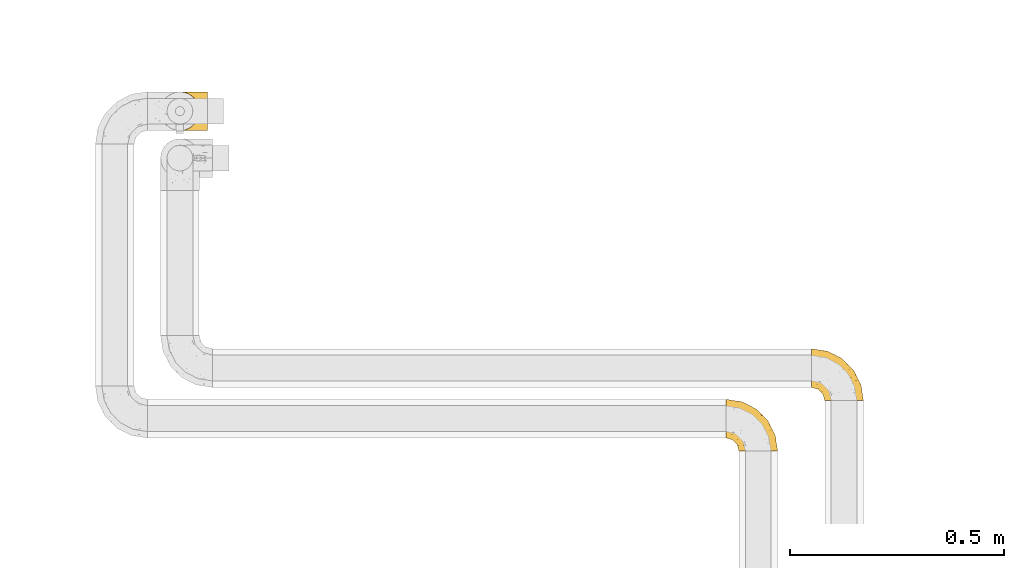
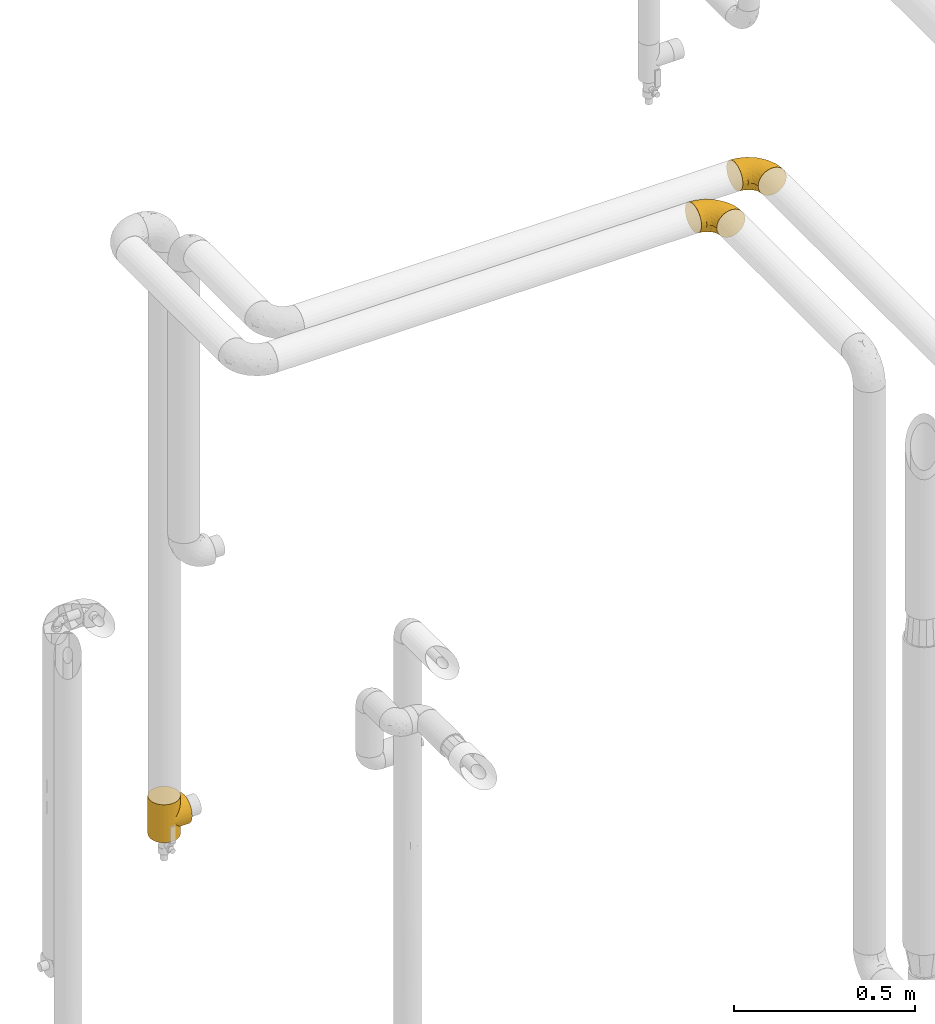
# One storey, part 118 of 827: 3 coverings.
"""IFC2X3 building model written with IfcOpenShell, lengths in millimetres."""

from ifc_helpers import new_model, entity, si_unit, converted_unit, derived_unit, direction, frame, origin, place, context, subcontext, project, spatial, faceted_brep, element, save


model = new_model("IFC2X3")

# Units and contexts
model_context = context("Model", 3, precision=0.01, world=origin(), true_north=direction((6.12303176911189e-17, 1.0)))
body_context = subcontext(model_context, "Body", "Model", "MODEL_VIEW")
ifc_project = project(units=[si_unit("LENGTHUNIT", "METRE", prefix="MILLI"), si_unit("AREAUNIT", "SQUARE_METRE"), si_unit("VOLUMEUNIT", "CUBIC_METRE"), converted_unit("PLANEANGLEUNIT", "DEGREE", entity("IfcRatioMeasure", 0.0174532925199433), si_unit("PLANEANGLEUNIT", "RADIAN"), dimensions=[0, 0, 0, 0, 0, 0, 0]), si_unit("MASSUNIT", "GRAM", prefix="KILO"), derived_unit("MASSDENSITYUNIT", [(si_unit("MASSUNIT", "GRAM", prefix="KILO"), 1), (si_unit("LENGTHUNIT", "METRE"), -3)]), derived_unit("MOMENTOFINERTIAUNIT", [(si_unit("LENGTHUNIT", "METRE"), 4)]), si_unit("TIMEUNIT", "SECOND"), si_unit("FREQUENCYUNIT", "HERTZ"), si_unit("THERMODYNAMICTEMPERATUREUNIT", "DEGREE_CELSIUS"), derived_unit("THERMALTRANSMITTANCEUNIT", [(si_unit("MASSUNIT", "GRAM", prefix="KILO"), 1), (si_unit("THERMODYNAMICTEMPERATUREUNIT", "KELVIN"), -1), (si_unit("TIMEUNIT", "SECOND"), -3)]), derived_unit("VOLUMETRICFLOWRATEUNIT", [(si_unit("LENGTHUNIT", "METRE"), 3), (si_unit("TIMEUNIT", "SECOND"), -1)]), derived_unit("MASSFLOWRATEUNIT", [(si_unit("MASSUNIT", "GRAM", prefix="KILO"), 1), (si_unit("TIMEUNIT", "SECOND"), -1)]), derived_unit("ROTATIONALFREQUENCYUNIT", [(si_unit("TIMEUNIT", "SECOND"), -1)]), si_unit("ELECTRICCURRENTUNIT", "AMPERE"), si_unit("ELECTRICVOLTAGEUNIT", "VOLT"), si_unit("POWERUNIT", "WATT"), si_unit("FORCEUNIT", "NEWTON", prefix="KILO"), si_unit("ILLUMINANCEUNIT", "LUX"), si_unit("LUMINOUSFLUXUNIT", "LUMEN"), si_unit("LUMINOUSINTENSITYUNIT", "CANDELA"), derived_unit("USERDEFINED", [(si_unit("MASSUNIT", "GRAM", prefix="KILO"), -1), (si_unit("LENGTHUNIT", "METRE"), -2), (si_unit("TIMEUNIT", "SECOND"), 3), (si_unit("LUMINOUSFLUXUNIT", "LUMEN"), 1)]), derived_unit("LINEARVELOCITYUNIT", [(si_unit("LENGTHUNIT", "METRE"), 1), (si_unit("TIMEUNIT", "SECOND"), -1)]), si_unit("PRESSUREUNIT", "PASCAL"), derived_unit("USERDEFINED", [(si_unit("LENGTHUNIT", "METRE"), -2), (si_unit("MASSUNIT", "GRAM", prefix="KILO"), 1), (si_unit("TIMEUNIT", "SECOND"), -2)]), derived_unit("LINEARFORCEUNIT", [(si_unit("MASSUNIT", "GRAM", prefix="KILO"), 1), (si_unit("LENGTHUNIT", "METRE"), 1), (si_unit("TIMEUNIT", "SECOND"), -2), (si_unit("LENGTHUNIT", "METRE"), -1)]), derived_unit("PLANARFORCEUNIT", [(si_unit("MASSUNIT", "GRAM", prefix="KILO"), 1), (si_unit("LENGTHUNIT", "METRE"), 1), (si_unit("TIMEUNIT", "SECOND"), -2), (si_unit("LENGTHUNIT", "METRE"), -2)])], contexts=[model_context])

# Site, building, storey
site_placement = place(None, origin())
site = spatial("IfcSite", under=ifc_project, at=site_placement, CompositionType="ELEMENT")
building_placement = place(site_placement, origin())
building = spatial("IfcBuilding", under=site, at=building_placement, CompositionType="ELEMENT")
storey_placement = place(building_placement, frame((0.0, 0.0, 28200.0)))
storey = spatial("IfcBuildingStorey", under=building, at=storey_placement, Name="08", CompositionType="ELEMENT", Elevation=28200.0)

# Coverings
covering_1_placement = place(storey_placement, frame((21222.65, 12443.23, 2353.25)))
element("IfcCovering", 1, at=covering_1_placement, inside=storey, Name=":ADSK_", ObjectType=":ADSK_", PredefinedType="INSULATION", context=body_context, shape_type="Brep", body=[
    faceted_brep([(1.6, 87.65, 90.76), (1.6, 97.19, 87.42), (1.6, 105.75, 82.04), (1.6, 112.9, 74.89), (1.6, 118.28, 66.33), (1.6, 121.61, 56.79), (1.6, 122.75, 46.75), (1.6, 121.61, 36.69), (1.6, 118.27, 27.15), (1.6, 112.89, 18.59), (1.6, 105.74, 11.44), (1.6, 97.18, 6.06), (1.6, 87.64, 2.73), (1.6, 77.6, 1.6), (1.6, 67.54, 2.73), (1.6, 58.0, 6.07), (1.6, 49.44, 11.45), (1.6, 42.29, 18.6), (1.6, 36.91, 27.16), (1.6, 33.58, 36.7), (1.6, 32.45, 46.75), (1.6, 33.58, 56.8), (1.6, 36.92, 66.34), (1.6, 42.3, 74.9), (1.6, 49.45, 82.05), (1.6, 58.01, 87.43), (1.6, 67.55, 90.76), (1.6, 77.6, 91.9), (33.98, 1.6, 35.06), (38.49, 1.6, 24.17), (45.67, 1.6, 14.82), (55.02, 1.6, 7.64), (65.91, 1.6, 3.13), (77.6, 1.6, 1.6), (89.28, 1.6, 3.13), (100.17, 1.6, 7.64), (109.52, 1.6, 14.82), (116.7, 1.6, 24.17), (121.21, 1.6, 35.06), (122.75, 1.6, 46.75), (121.21, 1.6, 58.43), (116.7, 1.6, 69.32), (109.52, 1.6, 78.67), (100.17, 1.6, 85.85), (89.28, 1.6, 90.36), (77.6, 1.6, 91.9), (65.91, 1.6, 90.36), (55.02, 1.6, 85.85), (45.67, 1.6, 78.67), (38.49, 1.6, 69.32), (33.98, 1.6, 58.43), (32.45, 1.6, 46.75), (72.81, 99.61, 46.75), (77.17, 95.26, 55.2), (86.21, 86.21, 46.75), (116.82, 39.03, 46.75), (118.49, 30.75, 54.53), (119.23, 23.8, 46.75), (105.14, 60.8, 59.63), (85.37, 85.37, 62.07), (89.33, 73.64, 71.86), (116.14, 31.01, 62.65), (105.06, 49.14, 71.33), (112.15, 23.88, 72.93), (22.95, 82.74, 91.2), (89.91, 43.48, 86.31), (103.39, 29.47, 80.89), (93.6, 56.38, 79.49), (51.41, 72.18, 90.68), (67.71, 72.24, 86.84), (43.53, 87.6, 87.38), (30.91, 107.24, 76.87), (23.58, 101.1, 83.73), (50.07, 95.16, 81.03), (30.68, 71.81, 91.9), (43.01, 63.57, 91.9), (55.34, 55.34, 91.9), (83.48, 23.66, 91.03), (94.96, 20.55, 87.58), (57.29, 107.97, 56.52), (39.03, 116.82, 46.75), (30.66, 117.03, 60.4), (71.81, 30.68, 91.9), (73.63, 21.51, 91.9), (75.46, 12.33, 91.9), (51.57, 106.17, 67.87), (73.13, 52.37, 90.35), (23.16, 114.51, 69.57), (23.8, 119.23, 46.75), (75.6, 78.37, 79.91), (12.33, 75.46, 91.9), (21.51, 73.63, 91.9), (50.46, 101.51, 74.99), (99.61, 72.81, 46.75), (63.57, 43.01, 91.9), (21.26, 92.6, 88.53), (69.54, 91.86, 72.65), (108.21, 55.92, 46.75), (68.42, 99.01, 62.97), (55.92, 108.21, 46.75), (19.36, 32.05, 66.2), (15.76, 30.22, 56.6), (26.13, 23.37, 59.89), (62.78, 28.43, 90.95), (63.65, 16.44, 90.22), (24.34, 37.1, 76.64), (28.46, 28.88, 71.58), (33.53, 33.93, 79.99), (39.46, 50.17, 89.54), (51.05, 40.57, 89.97), (10.94, 47.62, 81.32), (14.55, 39.9, 74.56), (22.21, 47.92, 84.15), (57.05, 34.27, 90.37), (54.0, 24.65, 87.82), (29.19, 62.6, 90.98), (18.85, 66.18, 90.96), (52.84, 11.74, 85.14), (31.47, 13.89, 58.11), (28.31, 17.02, 46.75), (43.0, 15.86, 78.39), (16.9, 57.71, 88.22), (35.98, 9.11, 66.06), (33.91, 18.55, 68.6), (9.97, 34.74, 63.78), (25.93, 54.95, 88.42), (35.61, 57.35, 90.61), (47.45, 22.03, 83.8), (38.26, 24.8, 77.98), (11.7, 69.07, 91.22), (30.13, 42.31, 83.46), (12.12, 29.63, 46.75), (17.02, 28.31, 46.75), (44.39, 30.23, 84.66), (39.83, 40.13, 86.33), (22.67, 22.67, 46.75), (29.63, 12.12, 46.75), (43.0, 15.86, 15.1), (47.45, 22.03, 9.69), (38.26, 24.8, 15.52), (44.38, 30.23, 8.83), (31.47, 13.88, 35.39), (10.93, 47.61, 12.18), (21.51, 73.63, 1.6), (18.84, 66.17, 2.53), (11.7, 69.07, 2.27), (15.76, 30.22, 36.9), (19.36, 32.04, 27.31), (26.14, 23.36, 33.62), (25.94, 54.93, 5.07), (22.21, 47.91, 9.36), (16.9, 57.69, 5.27), (35.98, 9.1, 27.43), (73.63, 21.51, 1.6), (75.46, 12.33, 1.6), (30.12, 42.29, 10.05), (24.33, 37.09, 16.87), (52.84, 11.74, 8.35), (63.65, 16.44, 3.27), (71.81, 30.68, 1.6), (28.45, 28.86, 21.94), (9.97, 34.74, 29.72), (43.01, 63.57, 1.6), (55.34, 55.34, 1.6), (39.46, 50.17, 3.96), (12.33, 75.46, 1.6), (14.54, 39.89, 18.95), (62.78, 28.43, 2.54), (57.05, 34.27, 3.12), (63.57, 43.01, 1.6), (29.2, 62.59, 2.51), (51.05, 40.57, 3.52), (39.81, 40.13, 7.17), (30.68, 71.81, 1.6), (33.52, 33.92, 13.52), (35.61, 57.34, 2.88), (54.0, 24.65, 5.67), (33.91, 18.54, 24.89), (103.39, 29.47, 12.6), (89.91, 43.48, 7.18), (93.6, 56.4, 14.0), (105.05, 49.17, 22.16), (89.27, 73.69, 21.61), (73.13, 52.37, 3.14), (67.67, 72.26, 6.65), (69.49, 91.88, 20.82), (85.36, 85.36, 31.41), (94.96, 20.55, 5.91), (83.48, 23.66, 2.46), (105.14, 60.8, 33.87), (116.13, 31.02, 30.84), (118.49, 30.75, 38.96), (112.15, 23.9, 20.56), (51.41, 72.17, 2.81), (43.51, 87.59, 6.1), (22.95, 82.74, 2.29), (30.66, 117.03, 33.08), (30.91, 107.23, 16.61), (57.3, 107.97, 36.96), (23.58, 101.08, 9.75), (51.56, 106.17, 25.61), (68.41, 99.01, 30.5), (23.16, 114.5, 23.91), (50.07, 95.15, 12.45), (50.45, 101.5, 18.49), (21.25, 92.59, 4.96), (75.56, 78.38, 13.56), (77.16, 95.27, 38.28)], [[[0, 1, 2, 3, 4, 5, 6, 7, 8, 9, 10, 11, 12, 13, 14, 15, 16, 17, 18, 19, 20, 21, 22, 23, 24, 25, 26, 27]], [[28, 29, 30, 31, 32, 33, 34, 35, 36, 37, 38, 39, 40, 41, 42, 43, 44, 45, 46, 47, 48, 49, 50, 51]], [[52, 53, 54]], [[55, 56, 57]], [[58, 59, 60]], [[61, 62, 63]], [[27, 64, 0]], [[65, 66, 67]], [[41, 40, 61]], [[68, 69, 70]], [[66, 43, 42]], [[63, 42, 41]], [[71, 72, 73]], [[72, 2, 1]], [[68, 74, 75, 76]], [[45, 44, 77]], [[43, 78, 44]], [[79, 80, 81]], [[77, 82, 83, 84, 45]], [[79, 81, 85]], [[71, 2, 72]], [[65, 86, 77]], [[4, 81, 5]], [[66, 65, 78]], [[4, 3, 87]], [[81, 88, 5]], [[63, 66, 42]], [[68, 70, 64]], [[67, 60, 89]], [[71, 3, 2]], [[64, 27, 90, 91, 74]], [[92, 71, 73]], [[40, 57, 56]], [[59, 93, 54]], [[86, 76, 94, 82]], [[1, 0, 95]], [[58, 62, 61]], [[60, 96, 89]], [[85, 81, 87]], [[56, 97, 58]], [[65, 67, 69]], [[87, 81, 4]], [[67, 89, 69]], [[61, 63, 41]], [[95, 72, 1]], [[73, 72, 70]], [[69, 73, 70]], [[73, 89, 96]], [[3, 71, 87]], [[85, 87, 71]], [[58, 61, 56]], [[59, 58, 93]], [[76, 86, 68]], [[69, 89, 73]], [[68, 86, 69]], [[65, 69, 86]], [[68, 64, 74]], [[95, 64, 70]], [[98, 79, 85]], [[79, 52, 99, 80]], [[66, 62, 67]], [[62, 58, 60]], [[62, 60, 67]], [[59, 98, 96]], [[59, 96, 60]], [[96, 85, 92]], [[88, 81, 80]], [[88, 6, 5]], [[66, 63, 62]], [[64, 95, 0]], [[72, 95, 70]], [[77, 44, 78]], [[86, 82, 77]], [[40, 39, 57]], [[96, 98, 85]], [[40, 56, 61]], [[66, 78, 43]], [[77, 78, 65]], [[79, 98, 53]], [[96, 92, 73]], [[85, 71, 92]], [[97, 56, 55]], [[97, 93, 58]], [[53, 98, 59]], [[54, 53, 59]], [[79, 53, 52]], [[100, 101, 102]], [[46, 45, 84, 83]], [[103, 104, 82]], [[82, 104, 83]], [[105, 106, 107]], [[108, 109, 76]], [[110, 111, 112]], [[103, 113, 114]], [[115, 74, 116]], [[48, 47, 117]], [[118, 102, 119]], [[49, 48, 120]], [[74, 91, 116]], [[116, 121, 115]], [[49, 122, 50]], [[123, 106, 102]], [[124, 111, 22]], [[125, 126, 115]], [[23, 22, 111]], [[24, 110, 121]], [[120, 127, 128]], [[90, 26, 129]], [[27, 26, 90]], [[121, 125, 115]], [[24, 121, 25]], [[130, 105, 107]], [[129, 25, 116]], [[21, 20, 131]], [[120, 123, 122]], [[112, 105, 130]], [[50, 118, 51]], [[21, 124, 22]], [[101, 131, 132]], [[117, 120, 48]], [[24, 23, 110]], [[127, 114, 133]], [[75, 108, 76]], [[107, 134, 130]], [[133, 114, 113]], [[129, 116, 91]], [[25, 121, 116]], [[121, 112, 125]], [[75, 74, 115]], [[101, 135, 102]], [[131, 101, 21]], [[101, 100, 124]], [[128, 127, 133]], [[119, 136, 51, 118]], [[104, 47, 46]], [[83, 104, 46]], [[117, 104, 114]], [[101, 124, 21]], [[111, 124, 100]], [[102, 118, 123]], [[133, 134, 107]], [[111, 110, 23]], [[114, 104, 103]], [[94, 76, 109]], [[121, 110, 112]], [[122, 118, 50]], [[134, 109, 108]], [[133, 107, 128]], [[112, 108, 125]], [[126, 125, 108]], [[108, 75, 126]], [[75, 115, 126]], [[109, 134, 133]], [[130, 108, 112]], [[108, 130, 134]], [[105, 112, 111]], [[111, 100, 105]], [[106, 105, 100]], [[102, 106, 100]], [[128, 106, 123]], [[90, 129, 91]], [[25, 129, 26]], [[104, 117, 47]], [[117, 114, 127]], [[82, 94, 103]], [[113, 94, 109]], [[94, 113, 103]], [[133, 113, 109]], [[106, 128, 107]], [[123, 120, 128]], [[120, 122, 49]], [[118, 122, 123]], [[135, 101, 132]], [[135, 119, 102]], [[117, 127, 120]], [[30, 29, 137]], [[138, 139, 140]], [[51, 136, 119, 141]], [[142, 17, 16]], [[143, 144, 145]], [[146, 147, 148]], [[149, 150, 151]], [[152, 29, 28]], [[33, 32, 153, 154]], [[150, 155, 156]], [[157, 31, 30]], [[153, 158, 159]], [[29, 152, 137]], [[148, 141, 119]], [[156, 160, 147]], [[148, 135, 146]], [[137, 138, 157]], [[19, 161, 146]], [[162, 163, 164]], [[14, 13, 165]], [[153, 32, 158]], [[147, 161, 166]], [[18, 17, 166]], [[167, 168, 169]], [[166, 150, 156]], [[151, 150, 142]], [[151, 170, 149]], [[151, 16, 15]], [[171, 140, 172]], [[165, 143, 145]], [[173, 170, 144]], [[142, 166, 17]], [[19, 131, 20]], [[144, 170, 151]], [[18, 161, 19]], [[173, 144, 143]], [[140, 139, 174]], [[171, 164, 163]], [[164, 172, 155]], [[151, 15, 144]], [[145, 15, 14]], [[173, 162, 170]], [[149, 175, 164]], [[19, 146, 131]], [[132, 131, 146]], [[160, 148, 147]], [[159, 158, 167]], [[135, 132, 146]], [[158, 32, 31]], [[157, 158, 31]], [[167, 158, 176]], [[166, 161, 18]], [[146, 161, 147]], [[148, 177, 141]], [[171, 168, 140]], [[171, 163, 169]], [[151, 142, 16]], [[166, 142, 150]], [[152, 141, 177]], [[51, 141, 28]], [[138, 140, 176]], [[172, 140, 174]], [[175, 149, 170]], [[164, 150, 149]], [[170, 162, 175]], [[162, 164, 175]], [[155, 172, 174]], [[171, 172, 164]], [[155, 174, 156]], [[164, 155, 150]], [[160, 156, 174]], [[147, 166, 156]], [[139, 160, 174]], [[148, 160, 177]], [[15, 145, 144]], [[165, 145, 14]], [[137, 157, 30]], [[158, 157, 176]], [[168, 167, 176]], [[169, 159, 167]], [[140, 168, 176]], [[169, 168, 171]], [[137, 177, 139]], [[160, 139, 177]], [[141, 152, 28]], [[137, 152, 177]], [[148, 119, 135]], [[157, 138, 176]], [[139, 138, 137]], [[178, 179, 180]], [[181, 180, 182]], [[179, 183, 184]], [[185, 186, 182]], [[187, 188, 179]], [[188, 33, 154, 153, 159]], [[181, 189, 190]], [[35, 34, 187]], [[191, 38, 190]], [[192, 178, 181]], [[179, 184, 180]], [[192, 190, 37]], [[37, 190, 38]], [[36, 35, 178]], [[54, 93, 186]], [[35, 187, 178]], [[193, 194, 184]], [[195, 173, 143, 165, 13]], [[195, 193, 173]], [[193, 163, 162, 173]], [[13, 12, 195]], [[8, 7, 196]], [[9, 197, 10]], [[198, 80, 99, 52]], [[196, 7, 88]], [[197, 199, 10]], [[182, 189, 181]], [[200, 198, 201]], [[200, 196, 198]], [[9, 8, 202]], [[194, 199, 203]], [[192, 37, 36]], [[80, 196, 88]], [[183, 159, 169, 163]], [[188, 34, 33]], [[202, 200, 197]], [[185, 203, 204]], [[202, 8, 196]], [[10, 199, 11]], [[12, 11, 205]], [[38, 191, 57]], [[189, 97, 191]], [[203, 199, 197]], [[205, 199, 194]], [[204, 203, 197]], [[184, 203, 206]], [[200, 202, 196]], [[197, 9, 202]], [[207, 54, 186]], [[97, 55, 191]], [[194, 203, 184]], [[183, 163, 193]], [[184, 206, 180]], [[183, 193, 184]], [[205, 195, 12]], [[193, 195, 194]], [[80, 198, 196]], [[207, 186, 201]], [[182, 180, 206]], [[181, 178, 180]], [[185, 182, 206]], [[182, 186, 189]], [[203, 185, 206]], [[185, 200, 201]], [[7, 6, 88]], [[178, 192, 36]], [[190, 192, 181]], [[199, 205, 11]], [[195, 205, 194]], [[159, 183, 188]], [[179, 188, 183]], [[57, 191, 55]], [[57, 39, 38]], [[189, 191, 190]], [[188, 187, 34]], [[178, 187, 179]], [[186, 93, 189]], [[197, 200, 204]], [[185, 204, 200]], [[189, 93, 97]], [[207, 198, 52]], [[185, 201, 186]], [[198, 207, 201]], [[54, 207, 52]]]),
])
covering_2_placement = place(storey_placement, frame((19703.25, 13073.62, 333.5)))
element("IfcCovering", 2, at=covering_2_placement, inside=storey, Name=":ADSK_", ObjectType=":ADSK_", PredefinedType="INSULATION", context=body_context, shape_type="Brep", body=[
    faceted_brep([(53.5, 2.1, 57.25), (46.75, 1.6, 0.0), (58.43, 3.13, 0.0), (69.32, 7.64, 0.0), (66.68, 6.23, 44.06), (72.92, 9.95, 37.83), (78.67, 14.82, 0.0), (46.75, 1.6, 64.0), (53.5, 2.1, 70.75), (46.75, 1.6, 128.0), (60.17, 3.64, 50.57), (83.88, 21.07, 26.86), (85.85, 24.17, 0.0), (88.08, 28.59, 22.66), (88.1, 29.61, 0.0), (90.36, 35.06, 0.0), (90.9, 37.3, 19.85), (91.9, 46.75, 0.0), (78.72, 14.87, 32.02), (91.9, 46.75, 18.85), (91.9, 46.75, 128.0), (90.9, 37.3, 108.15), (91.9, 46.75, 109.15), (90.63, 57.34, 20.11), (90.36, 58.43, 0.0), (87.15, 66.9, 23.6), (85.85, 69.32, 0.0), (82.05, 74.89, 28.7), (78.67, 78.67, 0.0), (90.63, 57.34, 107.89), (75.89, 81.23, 34.86), (69.06, 85.99, 41.68), (69.32, 85.85, 0.0), (61.82, 89.3, 48.92), (58.43, 90.36, 0.0), (54.34, 91.25, 56.41), (46.75, 91.9, 0.0), (46.75, 91.9, 64.0), (54.34, 91.25, 71.59), (46.75, 91.9, 128.0), (7.64, 69.32, 128.0), (3.13, 58.43, 128.0), (1.6, 46.75, 128.0), (3.13, 35.06, 128.0), (7.64, 24.17, 128.0), (14.82, 14.82, 128.0), (24.17, 7.64, 128.0), (35.06, 3.13, 128.0), (58.43, 3.13, 128.0), (69.32, 7.64, 128.0), (78.67, 14.82, 128.0), (85.85, 24.17, 128.0), (88.1, 29.61, 128.0), (90.36, 35.06, 128.0), (90.36, 58.43, 128.0), (85.85, 69.32, 128.0), (78.67, 78.67, 128.0), (69.32, 85.85, 128.0), (58.43, 90.36, 128.0), (35.06, 90.36, 128.0), (24.17, 85.85, 128.0), (14.82, 78.67, 128.0), (14.82, 14.82, 0.0), (7.64, 24.17, 0.0), (3.13, 35.06, 0.0), (1.6, 46.75, 0.0), (3.13, 58.43, 0.0), (7.64, 69.32, 0.0), (14.82, 78.67, 0.0), (24.17, 85.85, 0.0), (35.06, 90.36, 0.0), (35.06, 3.13, 0.0), (24.17, 7.64, 0.0), (60.17, 3.64, 77.43), (66.68, 6.23, 83.94), (72.92, 9.95, 90.17), (78.72, 14.87, 95.98), (83.88, 21.07, 101.14), (88.08, 28.59, 105.34), (87.15, 66.9, 104.4), (82.05, 74.89, 99.3), (75.89, 81.23, 93.14), (69.06, 85.99, 86.32), (61.82, 89.3, 79.08), (110.75, 14.82, 32.07), (110.75, 24.17, 24.9), (110.75, 29.61, 22.64), (110.75, 35.06, 20.39), (110.75, 46.75, 18.85), (110.75, 58.43, 20.39), (110.75, 69.32, 24.9), (110.75, 78.67, 32.07), (110.75, 85.85, 41.42), (110.75, 90.36, 52.31), (110.75, 91.9, 64.0), (110.75, 90.36, 75.69), (110.75, 85.85, 86.57), (110.75, 78.67, 95.93), (110.75, 69.32, 103.1), (110.75, 58.43, 107.61), (110.75, 46.75, 109.15), (110.75, 35.06, 107.61), (110.75, 29.61, 105.36), (110.75, 24.17, 103.1), (110.75, 14.82, 95.93), (110.75, 7.64, 86.57), (110.75, 3.13, 75.69), (110.75, 1.6, 64.0), (110.75, 3.13, 52.31), (110.75, 7.64, 41.42)], [[[0, 1, 2]], [[2, 3, 4]], [[5, 3, 6]], [[5, 4, 3]], [[0, 7, 1]], [[7, 8, 9]], [[4, 10, 2]], [[0, 2, 10]], [[11, 6, 12]], [[13, 12, 14, 15]], [[16, 15, 17]], [[11, 18, 6]], [[16, 13, 15]], [[19, 16, 17]], [[20, 21, 22]], [[11, 12, 13]], [[6, 18, 5]], [[23, 17, 24]], [[25, 24, 26]], [[27, 26, 28]], [[23, 19, 17]], [[22, 29, 20]], [[27, 25, 26]], [[23, 24, 25]], [[28, 30, 27]], [[31, 30, 32]], [[32, 30, 28]], [[33, 32, 34]], [[35, 34, 36]], [[33, 31, 32]], [[37, 35, 36]], [[38, 37, 39]], [[33, 34, 35]], [[40, 41, 42, 43, 44, 45, 46, 47, 9, 48, 49, 50, 51, 52, 53, 20, 54, 55, 56, 57, 58, 39, 59, 60, 61]], [[62, 63, 64, 65, 66, 67, 68, 69, 70, 36, 34, 32, 28, 26, 24, 17, 15, 14, 12, 6, 3, 2, 1, 71, 72]], [[63, 62, 45, 44]], [[42, 65, 64, 43]], [[44, 43, 64, 63]], [[46, 72, 71, 47]], [[1, 7, 9, 47, 71]], [[45, 62, 72, 46]], [[73, 74, 48]], [[8, 73, 48]], [[9, 8, 48]], [[49, 75, 50]], [[49, 48, 74]], [[75, 49, 74]], [[76, 77, 50]], [[78, 21, 53]], [[78, 53, 52, 51]], [[77, 78, 51]], [[50, 77, 51]], [[21, 20, 53]], [[76, 50, 75]], [[79, 80, 55]], [[29, 79, 54]], [[20, 29, 54]], [[54, 79, 55]], [[80, 56, 55]], [[80, 81, 56]], [[82, 83, 57]], [[83, 38, 58]], [[81, 57, 56]], [[81, 82, 57]], [[57, 83, 58]], [[38, 39, 58]], [[37, 36, 70, 59, 39]], [[59, 70, 69, 60]], [[69, 68, 61, 60]], [[61, 68, 67, 40]], [[40, 67, 66, 41]], [[41, 66, 65, 42]], [[84, 85, 86, 87, 88, 89, 90, 91, 92, 93, 94, 95, 96, 97, 98, 99, 100, 101, 102, 103, 104, 105, 106, 107, 108, 109]], [[16, 19, 88]], [[16, 88, 87]], [[13, 87, 86, 85]], [[13, 16, 87]], [[84, 18, 11]], [[13, 85, 11]], [[11, 85, 84]], [[5, 84, 109]], [[4, 109, 108]], [[0, 108, 107]], [[4, 5, 109]], [[0, 10, 108]], [[7, 0, 107]], [[4, 108, 10]], [[84, 5, 18]], [[8, 107, 106]], [[106, 105, 74]], [[75, 105, 104]], [[75, 74, 105]], [[8, 7, 107]], [[74, 73, 106]], [[8, 106, 73]], [[77, 104, 103]], [[78, 103, 102, 101]], [[21, 101, 100]], [[77, 76, 104]], [[21, 78, 101]], [[22, 21, 100]], [[77, 103, 78]], [[104, 76, 75]], [[29, 100, 99]], [[79, 99, 98]], [[80, 98, 97]], [[29, 22, 100]], [[80, 79, 98]], [[29, 99, 79]], [[97, 81, 80]], [[82, 81, 96]], [[96, 81, 97]], [[83, 96, 95]], [[38, 95, 94]], [[83, 82, 96]], [[37, 38, 94]], [[83, 95, 38]], [[35, 94, 93]], [[93, 92, 33]], [[30, 92, 91]], [[30, 31, 92]], [[35, 37, 94]], [[31, 33, 92]], [[35, 93, 33]], [[27, 91, 90]], [[25, 90, 89]], [[23, 89, 88]], [[25, 27, 90]], [[19, 23, 88]], [[25, 89, 23]], [[91, 27, 30]]]),
])
covering_3_placement = place(storey_placement, frame((21022.46, 12325.27, 2353.25)))
element("IfcCovering", 3, at=covering_3_placement, inside=storey, Name=":ADSK_", ObjectType=":ADSK_", PredefinedType="INSULATION", context=body_context, shape_type="Brep", body=[
    faceted_brep([(1.6, 87.65, 90.76), (1.6, 97.19, 87.42), (1.6, 105.75, 82.04), (1.6, 112.9, 74.89), (1.6, 118.28, 66.33), (1.6, 121.61, 56.79), (1.6, 122.75, 46.75), (1.6, 121.61, 36.69), (1.6, 118.27, 27.15), (1.6, 112.89, 18.59), (1.6, 105.74, 11.44), (1.6, 97.18, 6.06), (1.6, 87.64, 2.73), (1.6, 77.6, 1.6), (1.6, 67.54, 2.73), (1.6, 58.0, 6.07), (1.6, 49.44, 11.45), (1.6, 42.29, 18.6), (1.6, 36.91, 27.16), (1.6, 33.58, 36.7), (1.6, 32.45, 46.75), (1.6, 33.58, 56.8), (1.6, 36.92, 66.34), (1.6, 42.3, 74.9), (1.6, 49.45, 82.05), (1.6, 58.01, 87.43), (1.6, 67.55, 90.76), (1.6, 77.6, 91.9), (33.98, 1.6, 35.06), (38.49, 1.6, 24.17), (45.67, 1.6, 14.82), (55.02, 1.6, 7.64), (65.91, 1.6, 3.13), (77.6, 1.6, 1.6), (89.28, 1.6, 3.13), (100.17, 1.6, 7.64), (109.52, 1.6, 14.82), (116.7, 1.6, 24.17), (121.21, 1.6, 35.06), (122.75, 1.6, 46.75), (121.21, 1.6, 58.43), (116.7, 1.6, 69.32), (109.52, 1.6, 78.67), (100.17, 1.6, 85.85), (89.28, 1.6, 90.36), (77.6, 1.6, 91.9), (65.91, 1.6, 90.36), (55.02, 1.6, 85.85), (45.67, 1.6, 78.67), (38.49, 1.6, 69.32), (33.98, 1.6, 58.43), (32.45, 1.6, 46.75), (72.81, 99.61, 46.75), (77.17, 95.26, 55.2), (86.21, 86.21, 46.75), (116.82, 39.03, 46.75), (118.49, 30.75, 54.53), (119.23, 23.8, 46.75), (105.14, 60.8, 59.63), (85.37, 85.37, 62.07), (89.33, 73.64, 71.86), (116.14, 31.01, 62.65), (105.06, 49.14, 71.33), (112.15, 23.88, 72.93), (22.95, 82.74, 91.2), (89.91, 43.48, 86.31), (103.39, 29.47, 80.89), (93.6, 56.38, 79.49), (51.41, 72.18, 90.68), (67.71, 72.24, 86.84), (43.53, 87.6, 87.38), (30.91, 107.24, 76.87), (23.58, 101.1, 83.73), (50.07, 95.16, 81.03), (30.68, 71.81, 91.9), (43.01, 63.57, 91.9), (55.34, 55.34, 91.9), (83.48, 23.66, 91.03), (94.96, 20.55, 87.58), (57.29, 107.97, 56.52), (39.03, 116.82, 46.75), (30.66, 117.03, 60.4), (71.81, 30.68, 91.9), (73.63, 21.51, 91.9), (75.46, 12.33, 91.9), (51.57, 106.17, 67.87), (73.13, 52.37, 90.35), (23.16, 114.51, 69.57), (23.8, 119.23, 46.75), (75.6, 78.37, 79.91), (12.33, 75.46, 91.9), (21.51, 73.63, 91.9), (50.46, 101.51, 74.99), (99.61, 72.81, 46.75), (63.57, 43.01, 91.9), (21.26, 92.6, 88.53), (69.54, 91.86, 72.65), (108.21, 55.92, 46.75), (68.42, 99.01, 62.97), (55.92, 108.21, 46.75), (19.36, 32.05, 66.2), (15.76, 30.22, 56.6), (26.13, 23.37, 59.89), (62.78, 28.43, 90.95), (63.65, 16.44, 90.22), (24.34, 37.1, 76.64), (28.46, 28.88, 71.58), (33.53, 33.93, 79.99), (39.46, 50.17, 89.54), (51.05, 40.57, 89.97), (10.94, 47.62, 81.32), (14.55, 39.9, 74.56), (22.21, 47.92, 84.15), (57.05, 34.27, 90.37), (54.0, 24.65, 87.82), (29.19, 62.6, 90.98), (18.85, 66.18, 90.96), (52.84, 11.74, 85.14), (31.47, 13.89, 58.11), (28.31, 17.02, 46.75), (43.0, 15.86, 78.39), (16.9, 57.71, 88.22), (35.98, 9.11, 66.06), (33.91, 18.55, 68.6), (9.97, 34.74, 63.78), (25.93, 54.95, 88.42), (35.61, 57.35, 90.61), (47.45, 22.03, 83.8), (38.26, 24.8, 77.98), (11.7, 69.07, 91.22), (30.13, 42.31, 83.46), (12.12, 29.63, 46.75), (17.02, 28.31, 46.75), (44.39, 30.23, 84.66), (39.83, 40.13, 86.33), (22.67, 22.67, 46.75), (29.63, 12.12, 46.75), (43.0, 15.86, 15.1), (47.45, 22.03, 9.69), (38.26, 24.8, 15.52), (44.38, 30.23, 8.83), (31.47, 13.88, 35.39), (10.93, 47.61, 12.18), (21.51, 73.63, 1.6), (18.84, 66.17, 2.53), (11.7, 69.07, 2.27), (15.76, 30.22, 36.9), (19.36, 32.04, 27.31), (26.14, 23.36, 33.62), (25.94, 54.93, 5.07), (22.21, 47.91, 9.36), (16.9, 57.69, 5.27), (35.98, 9.1, 27.43), (73.63, 21.51, 1.6), (75.46, 12.33, 1.6), (30.12, 42.29, 10.05), (24.33, 37.09, 16.87), (52.84, 11.74, 8.35), (63.65, 16.44, 3.27), (71.81, 30.68, 1.6), (28.45, 28.86, 21.94), (9.97, 34.74, 29.72), (43.01, 63.57, 1.6), (55.34, 55.34, 1.6), (39.46, 50.17, 3.96), (12.33, 75.46, 1.6), (14.54, 39.89, 18.95), (62.78, 28.43, 2.54), (57.05, 34.27, 3.12), (63.57, 43.01, 1.6), (29.2, 62.59, 2.51), (51.05, 40.57, 3.52), (39.81, 40.13, 7.17), (30.68, 71.81, 1.6), (33.52, 33.92, 13.52), (35.61, 57.34, 2.88), (54.0, 24.65, 5.67), (33.91, 18.54, 24.89), (103.39, 29.47, 12.6), (89.91, 43.48, 7.18), (93.6, 56.4, 14.0), (105.05, 49.17, 22.16), (89.27, 73.69, 21.61), (73.13, 52.37, 3.14), (67.67, 72.26, 6.65), (69.49, 91.88, 20.82), (85.36, 85.36, 31.41), (94.96, 20.55, 5.91), (83.48, 23.66, 2.46), (105.14, 60.8, 33.87), (116.13, 31.02, 30.84), (118.49, 30.75, 38.96), (112.15, 23.9, 20.56), (51.41, 72.17, 2.81), (43.51, 87.59, 6.1), (22.95, 82.74, 2.29), (30.66, 117.03, 33.08), (30.91, 107.23, 16.61), (57.3, 107.97, 36.96), (23.58, 101.08, 9.75), (51.56, 106.17, 25.61), (68.41, 99.01, 30.5), (23.16, 114.5, 23.91), (50.07, 95.15, 12.45), (50.45, 101.5, 18.49), (21.25, 92.59, 4.96), (75.56, 78.38, 13.56), (77.16, 95.27, 38.28)], [[[0, 1, 2, 3, 4, 5, 6, 7, 8, 9, 10, 11, 12, 13, 14, 15, 16, 17, 18, 19, 20, 21, 22, 23, 24, 25, 26, 27]], [[28, 29, 30, 31, 32, 33, 34, 35, 36, 37, 38, 39, 40, 41, 42, 43, 44, 45, 46, 47, 48, 49, 50, 51]], [[52, 53, 54]], [[55, 56, 57]], [[58, 59, 60]], [[61, 62, 63]], [[27, 64, 0]], [[65, 66, 67]], [[41, 40, 61]], [[68, 69, 70]], [[66, 43, 42]], [[63, 42, 41]], [[71, 72, 73]], [[72, 2, 1]], [[68, 74, 75, 76]], [[45, 44, 77]], [[43, 78, 44]], [[79, 80, 81]], [[77, 82, 83, 84, 45]], [[79, 81, 85]], [[71, 2, 72]], [[65, 86, 77]], [[4, 81, 5]], [[66, 65, 78]], [[4, 3, 87]], [[81, 88, 5]], [[63, 66, 42]], [[68, 70, 64]], [[67, 60, 89]], [[71, 3, 2]], [[64, 27, 90, 91, 74]], [[92, 71, 73]], [[40, 57, 56]], [[59, 93, 54]], [[86, 76, 94, 82]], [[1, 0, 95]], [[58, 62, 61]], [[60, 96, 89]], [[85, 81, 87]], [[56, 97, 58]], [[65, 67, 69]], [[87, 81, 4]], [[67, 89, 69]], [[61, 63, 41]], [[95, 72, 1]], [[73, 72, 70]], [[69, 73, 70]], [[73, 89, 96]], [[3, 71, 87]], [[85, 87, 71]], [[58, 61, 56]], [[59, 58, 93]], [[76, 86, 68]], [[69, 89, 73]], [[68, 86, 69]], [[65, 69, 86]], [[68, 64, 74]], [[95, 64, 70]], [[98, 79, 85]], [[79, 52, 99, 80]], [[66, 62, 67]], [[62, 58, 60]], [[62, 60, 67]], [[59, 98, 96]], [[59, 96, 60]], [[96, 85, 92]], [[88, 81, 80]], [[88, 6, 5]], [[66, 63, 62]], [[64, 95, 0]], [[72, 95, 70]], [[77, 44, 78]], [[86, 82, 77]], [[40, 39, 57]], [[96, 98, 85]], [[40, 56, 61]], [[66, 78, 43]], [[77, 78, 65]], [[79, 98, 53]], [[96, 92, 73]], [[85, 71, 92]], [[97, 56, 55]], [[97, 93, 58]], [[53, 98, 59]], [[54, 53, 59]], [[79, 53, 52]], [[100, 101, 102]], [[46, 45, 84, 83]], [[103, 104, 82]], [[82, 104, 83]], [[105, 106, 107]], [[108, 109, 76]], [[110, 111, 112]], [[103, 113, 114]], [[115, 74, 116]], [[48, 47, 117]], [[118, 102, 119]], [[49, 48, 120]], [[74, 91, 116]], [[116, 121, 115]], [[49, 122, 50]], [[123, 106, 102]], [[124, 111, 22]], [[125, 126, 115]], [[23, 22, 111]], [[24, 110, 121]], [[120, 127, 128]], [[90, 26, 129]], [[27, 26, 90]], [[121, 125, 115]], [[24, 121, 25]], [[130, 105, 107]], [[129, 25, 116]], [[21, 20, 131]], [[120, 123, 122]], [[112, 105, 130]], [[50, 118, 51]], [[21, 124, 22]], [[101, 131, 132]], [[117, 120, 48]], [[24, 23, 110]], [[127, 114, 133]], [[75, 108, 76]], [[107, 134, 130]], [[133, 114, 113]], [[129, 116, 91]], [[25, 121, 116]], [[121, 112, 125]], [[75, 74, 115]], [[101, 135, 102]], [[131, 101, 21]], [[101, 100, 124]], [[128, 127, 133]], [[119, 136, 51, 118]], [[104, 47, 46]], [[83, 104, 46]], [[117, 104, 114]], [[101, 124, 21]], [[111, 124, 100]], [[102, 118, 123]], [[133, 134, 107]], [[111, 110, 23]], [[114, 104, 103]], [[94, 76, 109]], [[121, 110, 112]], [[122, 118, 50]], [[134, 109, 108]], [[133, 107, 128]], [[112, 108, 125]], [[126, 125, 108]], [[108, 75, 126]], [[75, 115, 126]], [[109, 134, 133]], [[130, 108, 112]], [[108, 130, 134]], [[105, 112, 111]], [[111, 100, 105]], [[106, 105, 100]], [[102, 106, 100]], [[128, 106, 123]], [[90, 129, 91]], [[25, 129, 26]], [[104, 117, 47]], [[117, 114, 127]], [[82, 94, 103]], [[113, 94, 109]], [[94, 113, 103]], [[133, 113, 109]], [[106, 128, 107]], [[123, 120, 128]], [[120, 122, 49]], [[118, 122, 123]], [[135, 101, 132]], [[135, 119, 102]], [[117, 127, 120]], [[30, 29, 137]], [[138, 139, 140]], [[51, 136, 119, 141]], [[142, 17, 16]], [[143, 144, 145]], [[146, 147, 148]], [[149, 150, 151]], [[152, 29, 28]], [[33, 32, 153, 154]], [[150, 155, 156]], [[157, 31, 30]], [[153, 158, 159]], [[29, 152, 137]], [[148, 141, 119]], [[156, 160, 147]], [[148, 135, 146]], [[137, 138, 157]], [[19, 161, 146]], [[162, 163, 164]], [[14, 13, 165]], [[153, 32, 158]], [[147, 161, 166]], [[18, 17, 166]], [[167, 168, 169]], [[166, 150, 156]], [[151, 150, 142]], [[151, 170, 149]], [[151, 16, 15]], [[171, 140, 172]], [[165, 143, 145]], [[173, 170, 144]], [[142, 166, 17]], [[19, 131, 20]], [[144, 170, 151]], [[18, 161, 19]], [[173, 144, 143]], [[140, 139, 174]], [[171, 164, 163]], [[164, 172, 155]], [[151, 15, 144]], [[145, 15, 14]], [[173, 162, 170]], [[149, 175, 164]], [[19, 146, 131]], [[132, 131, 146]], [[160, 148, 147]], [[159, 158, 167]], [[135, 132, 146]], [[158, 32, 31]], [[157, 158, 31]], [[167, 158, 176]], [[166, 161, 18]], [[146, 161, 147]], [[148, 177, 141]], [[171, 168, 140]], [[171, 163, 169]], [[151, 142, 16]], [[166, 142, 150]], [[152, 141, 177]], [[51, 141, 28]], [[138, 140, 176]], [[172, 140, 174]], [[175, 149, 170]], [[164, 150, 149]], [[170, 162, 175]], [[162, 164, 175]], [[155, 172, 174]], [[171, 172, 164]], [[155, 174, 156]], [[164, 155, 150]], [[160, 156, 174]], [[147, 166, 156]], [[139, 160, 174]], [[148, 160, 177]], [[15, 145, 144]], [[165, 145, 14]], [[137, 157, 30]], [[158, 157, 176]], [[168, 167, 176]], [[169, 159, 167]], [[140, 168, 176]], [[169, 168, 171]], [[137, 177, 139]], [[160, 139, 177]], [[141, 152, 28]], [[137, 152, 177]], [[148, 119, 135]], [[157, 138, 176]], [[139, 138, 137]], [[178, 179, 180]], [[181, 180, 182]], [[179, 183, 184]], [[185, 186, 182]], [[187, 188, 179]], [[188, 33, 154, 153, 159]], [[181, 189, 190]], [[35, 34, 187]], [[191, 38, 190]], [[192, 178, 181]], [[179, 184, 180]], [[192, 190, 37]], [[37, 190, 38]], [[36, 35, 178]], [[54, 93, 186]], [[35, 187, 178]], [[193, 194, 184]], [[195, 173, 143, 165, 13]], [[195, 193, 173]], [[193, 163, 162, 173]], [[13, 12, 195]], [[8, 7, 196]], [[9, 197, 10]], [[198, 80, 99, 52]], [[196, 7, 88]], [[197, 199, 10]], [[182, 189, 181]], [[200, 198, 201]], [[200, 196, 198]], [[9, 8, 202]], [[194, 199, 203]], [[192, 37, 36]], [[80, 196, 88]], [[183, 159, 169, 163]], [[188, 34, 33]], [[202, 200, 197]], [[185, 203, 204]], [[202, 8, 196]], [[10, 199, 11]], [[12, 11, 205]], [[38, 191, 57]], [[189, 97, 191]], [[203, 199, 197]], [[205, 199, 194]], [[204, 203, 197]], [[184, 203, 206]], [[200, 202, 196]], [[197, 9, 202]], [[207, 54, 186]], [[97, 55, 191]], [[194, 203, 184]], [[183, 163, 193]], [[184, 206, 180]], [[183, 193, 184]], [[205, 195, 12]], [[193, 195, 194]], [[80, 198, 196]], [[207, 186, 201]], [[182, 180, 206]], [[181, 178, 180]], [[185, 182, 206]], [[182, 186, 189]], [[203, 185, 206]], [[185, 200, 201]], [[7, 6, 88]], [[178, 192, 36]], [[190, 192, 181]], [[199, 205, 11]], [[195, 205, 194]], [[159, 183, 188]], [[179, 188, 183]], [[57, 191, 55]], [[57, 39, 38]], [[189, 191, 190]], [[188, 187, 34]], [[178, 187, 179]], [[186, 93, 189]], [[197, 200, 204]], [[185, 204, 200]], [[189, 93, 97]], [[207, 198, 52]], [[185, 201, 186]], [[198, 207, 201]], [[54, 207, 52]]]),
])

save(model, "model.ifc")
